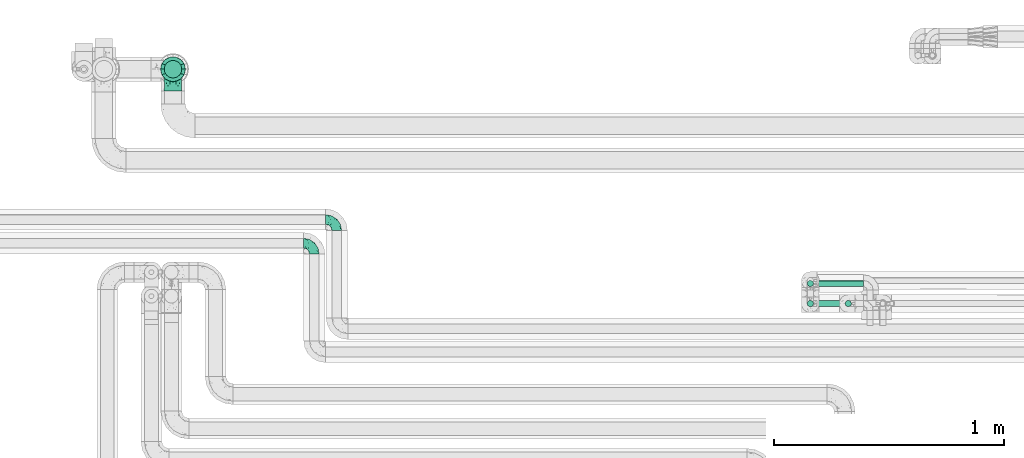
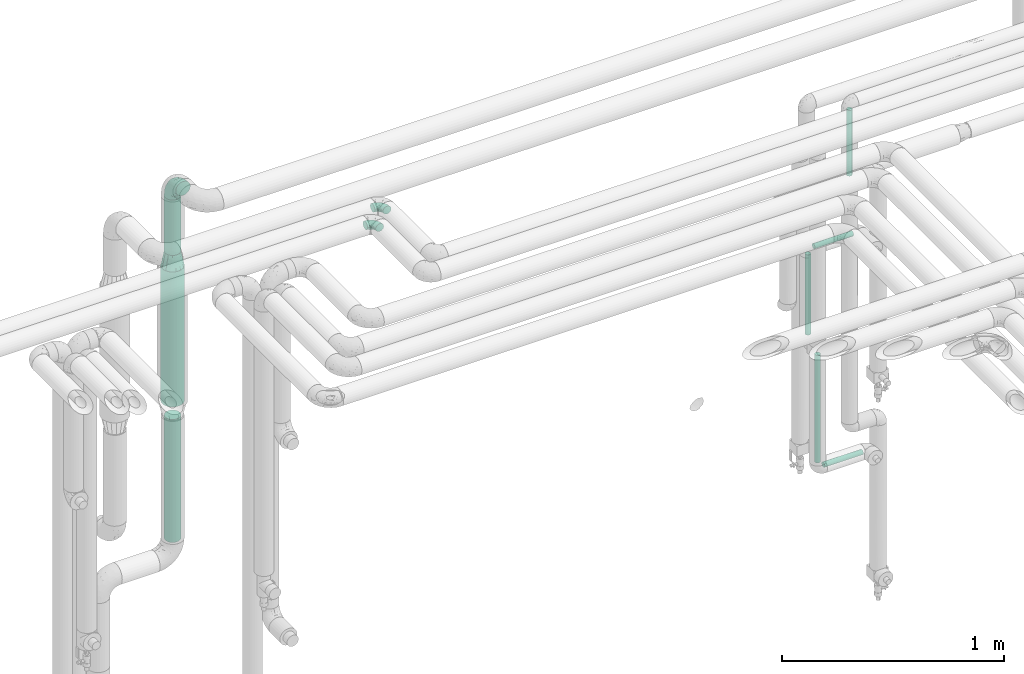
# One storey, part 643 of 824: 8 flow segments, 4 flow fittings.
"""IFC2X3 building model written with IfcOpenShell, lengths in millimetres."""

from ifc_helpers import new_model, entity, si_unit, converted_unit, derived_unit, direction, frame, origin, origin_2d_with_axis, place, context, subcontext, project, spatial, circle, extrude, faceted_brep, source, transform, mapped, material, type_object, type_shapes, element, save


model = new_model("IFC2X3")

# Units and contexts
model_context = context("Model", 3, precision=0.01, world=origin(), true_north=direction((6.12303176911189e-17, 1.0)))
body_context = subcontext(model_context, "Body", "Model", "MODEL_VIEW")
ifc_project = project(units=[si_unit("LENGTHUNIT", "METRE", prefix="MILLI"), si_unit("AREAUNIT", "SQUARE_METRE"), si_unit("VOLUMEUNIT", "CUBIC_METRE"), converted_unit("PLANEANGLEUNIT", "DEGREE", entity("IfcRatioMeasure", 0.0174532925199433), si_unit("PLANEANGLEUNIT", "RADIAN"), dimensions=[0, 0, 0, 0, 0, 0, 0]), si_unit("MASSUNIT", "GRAM", prefix="KILO"), derived_unit("MASSDENSITYUNIT", [(si_unit("MASSUNIT", "GRAM", prefix="KILO"), 1), (si_unit("LENGTHUNIT", "METRE"), -3)]), derived_unit("MOMENTOFINERTIAUNIT", [(si_unit("LENGTHUNIT", "METRE"), 4)]), si_unit("TIMEUNIT", "SECOND"), si_unit("FREQUENCYUNIT", "HERTZ"), si_unit("THERMODYNAMICTEMPERATUREUNIT", "DEGREE_CELSIUS"), derived_unit("THERMALTRANSMITTANCEUNIT", [(si_unit("MASSUNIT", "GRAM", prefix="KILO"), 1), (si_unit("THERMODYNAMICTEMPERATUREUNIT", "KELVIN"), -1), (si_unit("TIMEUNIT", "SECOND"), -3)]), derived_unit("VOLUMETRICFLOWRATEUNIT", [(si_unit("LENGTHUNIT", "METRE"), 3), (si_unit("TIMEUNIT", "SECOND"), -1)]), derived_unit("MASSFLOWRATEUNIT", [(si_unit("MASSUNIT", "GRAM", prefix="KILO"), 1), (si_unit("TIMEUNIT", "SECOND"), -1)]), derived_unit("ROTATIONALFREQUENCYUNIT", [(si_unit("TIMEUNIT", "SECOND"), -1)]), si_unit("ELECTRICCURRENTUNIT", "AMPERE"), si_unit("ELECTRICVOLTAGEUNIT", "VOLT"), si_unit("POWERUNIT", "WATT"), si_unit("FORCEUNIT", "NEWTON", prefix="KILO"), si_unit("ILLUMINANCEUNIT", "LUX"), si_unit("LUMINOUSFLUXUNIT", "LUMEN"), si_unit("LUMINOUSINTENSITYUNIT", "CANDELA"), derived_unit("USERDEFINED", [(si_unit("MASSUNIT", "GRAM", prefix="KILO"), -1), (si_unit("LENGTHUNIT", "METRE"), -2), (si_unit("TIMEUNIT", "SECOND"), 3), (si_unit("LUMINOUSFLUXUNIT", "LUMEN"), 1)]), derived_unit("LINEARVELOCITYUNIT", [(si_unit("LENGTHUNIT", "METRE"), 1), (si_unit("TIMEUNIT", "SECOND"), -1)]), si_unit("PRESSUREUNIT", "PASCAL"), derived_unit("USERDEFINED", [(si_unit("LENGTHUNIT", "METRE"), -2), (si_unit("MASSUNIT", "GRAM", prefix="KILO"), 1), (si_unit("TIMEUNIT", "SECOND"), -2)]), derived_unit("LINEARFORCEUNIT", [(si_unit("MASSUNIT", "GRAM", prefix="KILO"), 1), (si_unit("LENGTHUNIT", "METRE"), 1), (si_unit("TIMEUNIT", "SECOND"), -2), (si_unit("LENGTHUNIT", "METRE"), -1)]), derived_unit("PLANARFORCEUNIT", [(si_unit("MASSUNIT", "GRAM", prefix="KILO"), 1), (si_unit("LENGTHUNIT", "METRE"), 1), (si_unit("TIMEUNIT", "SECOND"), -2), (si_unit("LENGTHUNIT", "METRE"), -2)])], contexts=[model_context])

# Site, building, storey
site_placement = place(None, origin())
site = spatial("IfcSite", under=ifc_project, at=site_placement, CompositionType="ELEMENT")
building_placement = place(site_placement, origin())
building = spatial("IfcBuilding", under=site, at=building_placement, CompositionType="ELEMENT")
storey_placement = place(building_placement, frame((0.0, 0.0, 28200.0)))
storey = spatial("IfcBuildingStorey", under=building, at=storey_placement, CompositionType="ELEMENT", Elevation=28200.0)

# Flow segments
pipe_segment_type_1 = type_object("IfcPipeSegmentType", PredefinedType="NOTDEFINED")
flow_segment_1_placement = place(storey_placement, frame((31716.11, 19313.84, 2600.0)))
element("IfcFlowSegment", 1, at=flow_segment_1_placement, inside=storey, type_object=pipe_segment_type_1, context=body_context, shape_type="SweptSolid", body=[
    extrude(circle(Radius=38.0, at=origin_2d_with_axis()), frame((39.6, 39.6, 0.0)), (0.0, 0.0, 1.0), 305.000000000013),
])
flow_segment_2_placement = place(storey_placement, frame((31716.31, 19313.84, 1020.26)))
element("IfcFlowSegment", 2, at=flow_segment_2_placement, inside=storey, type_object=pipe_segment_type_1, context=body_context, shape_type="SweptSolid", body=[
    extrude(circle(Radius=38.0, at=origin_2d_with_axis()), frame((39.6, 39.6, 0.0), z_axis=(0.0, 0.0, 1.0), x_axis=(-1.0, 0.0, 0.0)), (0.0, 0.0, 1.0), 676.738359999959),
])
flow_segment_3_placement = place(storey_placement, frame((31700.11, 19297.84, 1777.0)))
element("IfcFlowSegment", 3, at=flow_segment_3_placement, inside=storey, type_object=pipe_segment_type_1, context=body_context, shape_type="SweptSolid", body=[
    extrude(circle(Radius=54.0, at=origin_2d_with_axis()), frame((55.6, 55.6, 0.0), z_axis=(0.0, 0.0, 1.0), x_axis=(-1.0, 0.0, 0.0)), (0.0, 0.0, 1.0), 743.000000000004),
])
pipe_segment_type_2 = type_object("IfcPipeSegmentType", PredefinedType="NOTDEFINED")
flow_segment_4_placement = place(storey_placement, frame((34510.39, 18319.92, 1089.1)))
element("IfcFlowSegment", 4, at=flow_segment_4_placement, inside=storey, type_object=pipe_segment_type_2, context=body_context, shape_type="SweptSolid", body=[
    extrude(circle(Radius=13.4, at=origin_2d_with_axis()), frame((15.0, 15.0, 0.0)), (0.0, 0.0, 1.0), 591.900000000008),
])
flow_segment_5_placement = place(storey_placement, frame((34554.49, 18319.92, 1045.0)))
element("IfcFlowSegment", 5, at=flow_segment_5_placement, inside=storey, type_object=pipe_segment_type_2, context=body_context, shape_type="SweptSolid", body=[
    extrude(circle(Radius=13.4, at=origin_2d_with_axis()), frame((0.0, 15.0, 15.0), z_axis=(1.0, 0.0, 0.0), x_axis=(0.0, -1.0, 0.0)), (0.0, 0.0, 1.0), 201.799999999997),
])
flow_segment_6_placement = place(storey_placement, frame((34554.49, 18406.91, 2195.0)))
element("IfcFlowSegment", 6, at=flow_segment_6_placement, inside=storey, type_object=pipe_segment_type_2, context=body_context, shape_type="SweptSolid", body=[
    extrude(circle(Radius=13.4, at=origin_2d_with_axis()), frame((0.0, 15.0, 15.0), z_axis=(1.0, 0.0, 0.0), x_axis=(0.0, 1.0, 0.0)), (0.0, 0.0, 1.0), 201.799999999997),
])
flow_segment_7_placement = place(storey_placement, frame((34510.39, 18406.91, 1739.1)))
element("IfcFlowSegment", 7, at=flow_segment_7_placement, inside=storey, type_object=pipe_segment_type_2, context=body_context, shape_type="SweptSolid", body=[
    extrude(circle(Radius=13.4, at=origin_2d_with_axis()), frame((15.0, 15.0, 0.0)), (0.0, 0.0, 1.0), 441.800000000021),
])
flow_segment_8_placement = place(storey_placement, frame((34675.43, 18319.92, 2609.0)))
element("IfcFlowSegment", 8, at=flow_segment_8_placement, inside=storey, type_object=pipe_segment_type_2, context=body_context, shape_type="SweptSolid", body=[
    extrude(circle(Radius=13.4, at=origin_2d_with_axis()), frame((15.0, 15.0, 0.0), z_axis=(0.0, 0.0, 1.0), x_axis=(-1.0, 0.0, 0.0)), (0.0, 0.0, 1.0), 362.066280646175),
])

# Flow fittings
ifc_material = material()
pipe_fitting_type_1 = type_object("IfcPipeFittingType", PredefinedType="NOTDEFINED", material=ifc_material)
shared_shape_1 = source(origin(), body_context, "Body", "Brep", [
    faceted_brep([(-48.0, 10.6, -18.36), (-48.0, 5.49, -20.48), (-48.0, 0.0, -21.2), (-48.0, -5.49, -20.48), (-48.0, -10.6, -18.36), (-48.0, -14.99, -14.99), (-48.0, -18.36, -10.6), (-48.0, -20.48, -5.49), (-48.0, -21.2, 0.0), (-48.0, -20.48, 5.49), (-48.0, -18.36, 10.6), (-48.0, -14.99, 14.99), (-48.0, -10.6, 18.36), (-48.0, -5.49, 20.48), (-48.0, 0.0, 21.2), (-48.0, 5.49, 20.48), (-48.0, 10.6, 18.36), (-48.0, 14.99, 14.99), (-48.0, 18.36, 10.6), (-48.0, 20.48, 5.49), (-48.0, 21.2, 0.0), (-48.0, 20.48, -5.49), (-48.0, 18.36, -10.6), (-48.0, 14.99, -14.99), (0.0, 48.0, -21.2), (-5.49, 48.0, -20.48), (-10.6, 48.0, -18.36), (-14.99, 48.0, -14.99), (-18.36, 48.0, -10.6), (-20.48, 48.0, -5.49), (-21.2, 48.0, 0.0), (-20.48, 48.0, 5.49), (-18.36, 48.0, 10.6), (-14.99, 48.0, 14.99), (-10.6, 48.0, 18.36), (-5.49, 48.0, 20.48), (0.0, 48.0, 21.2), (5.49, 48.0, 20.48), (10.6, 48.0, 18.36), (14.99, 48.0, 14.99), (18.36, 48.0, 10.6), (20.48, 48.0, 5.49), (21.2, 48.0, 0.0), (20.48, 48.0, -5.49), (18.36, 48.0, -10.6), (14.99, 48.0, -14.99), (10.6, 48.0, -18.36), (5.49, 48.0, -20.48), (-35.25, -16.22, 12.01), (-34.76, -18.57, 0.0), (-20.87, -12.37, 10.9), (-31.49, -11.78, 15.9), (-37.0, -2.58, 20.86), (-33.89, 3.62, 21.15), (-31.81, -18.14, 6.76), (-5.78, 5.78, 17.67), (-19.42, -4.1, 17.86), (-9.6, -3.39, 13.73), (-35.44, -7.73, 19.13), (11.78, 31.49, 15.9), (-5.93, -5.46, 6.95), (-18.45, -13.78, 5.46), (-10.29, -8.43, 0.0), (-24.6, 0.55, 20.62), (-37.28, 17.94, 13.81), (-33.38, 22.85, 9.59), (-41.46, 20.06, 8.75), (-29.51, 20.45, 15.16), (-15.04, 10.79, 21.13), (-7.08, 16.98, 20.93), (-8.39, 23.51, 21.15), (-40.86, 13.03, 17.26), (-8.05, 41.26, 19.83), (-3.21, 35.97, 21.14), (8.53, 19.66, 14.74), (4.1, 19.42, 17.86), (-37.72, 22.66, 4.78), (-37.07, 8.58, 19.98), (-13.0, 5.43, 19.97), (-3.78, 13.93, 19.7), (3.02, 8.69, 13.43), (-2.27, -0.05, 10.65), (6.22, 6.99, 7.09), (-22.25, 34.6, 9.45), (18.14, 31.81, 6.76), (16.22, 35.25, 12.01), (12.37, 20.87, 10.9), (7.73, 35.44, 19.13), (-21.52, -15.93, 0.0), (2.58, 37.0, 20.86), (18.57, 34.76, 0.0), (13.78, 18.45, 5.46), (15.93, 21.52, 0.0), (-20.03, -8.54, 14.9), (-28.6, 28.6, 5.16), (-24.79, 34.6, 0.0), (-34.6, 24.79, 0.0), (-22.81, 37.41, 4.68), (-23.36, 26.33, 14.79), (-13.68, 37.05, 17.49), (-17.72, 38.12, 13.73), (-26.25, 27.3, 11.24), (-9.71, 32.34, 20.14), (-17.26, 25.6, 18.71), (-26.33, 9.99, 20.77), (-24.06, 6.05, 21.2), (-25.02, 15.46, 19.56), (-24.3, 20.72, 17.57), (-31.95, 15.23, 17.8), (-13.53, 24.7, 20.21), (-17.6, 17.6, 20.6), (-0.55, 24.6, 20.62), (-11.41, -7.48, 10.43), (0.93, -0.93, 0.0), (8.43, 10.29, 0.0), (-11.41, -7.48, -10.43), (-20.1, -8.84, -14.66), (-9.6, -3.39, -13.73), (7.73, 35.44, -19.13), (4.1, 19.42, -17.86), (-0.55, 24.6, -20.62), (-38.12, 17.72, -13.73), (-37.05, 13.68, -17.49), (-32.34, 9.71, -20.14), (-41.26, 8.05, -19.83), (-37.41, 22.81, -4.68), (-23.51, 8.39, -21.15), (-35.97, 3.21, -21.14), (-28.6, 28.6, -5.16), (-31.81, -18.14, -6.76), (-18.45, -13.78, -5.46), (-25.6, 17.26, -18.71), (-19.42, -4.1, -17.86), (-17.94, 37.28, -13.81), (-22.85, 33.38, -9.59), (-20.06, 41.46, -8.75), (-31.49, -11.78, -15.9), (-35.25, -16.22, -12.01), (8.53, 19.66, -14.74), (11.78, 31.49, -15.9), (-9.99, 26.33, -20.77), (-6.05, 24.06, -21.2), (-10.79, 15.04, -21.13), (-37.0, -2.58, -20.86), (-16.98, 7.08, -20.93), (-5.43, 13.0, -19.97), (-13.93, 3.78, -19.7), (-20.87, -12.37, -10.9), (-26.33, 23.36, -14.79), (-22.66, 37.72, -4.78), (13.78, 18.45, -5.46), (18.14, 31.81, -6.76), (-15.46, 25.02, -19.56), (-20.72, 24.3, -17.57), (16.22, 35.25, -12.01), (-13.03, 40.86, -17.26), (-8.58, 37.07, -19.98), (2.58, 37.0, -20.86), (-3.62, 33.89, -21.15), (-34.6, 22.25, -9.45), (6.22, 6.99, -7.09), (-20.45, 29.51, -15.16), (-35.44, -7.73, -19.13), (12.37, 20.87, -10.9), (-27.3, 26.25, -11.24), (-15.23, 31.95, -17.8), (-24.7, 13.53, -20.21), (-24.6, 0.55, -20.62), (-5.78, 5.78, -17.67), (-17.6, 17.6, -20.6), (3.02, 8.69, -13.43), (-5.93, -5.46, -6.95), (-2.27, -0.05, -10.65)], [[[0, 1, 2, 3, 4, 5, 6, 7, 8, 9, 10, 11, 12, 13, 14, 15, 16, 17, 18, 19, 20, 21, 22, 23]], [[24, 25, 26, 27, 28, 29, 30, 31, 32, 33, 34, 35, 36, 37, 38, 39, 40, 41, 42, 43, 44, 45, 46, 47]], [[10, 48, 11]], [[9, 8, 49]], [[48, 50, 51]], [[14, 52, 53]], [[10, 54, 48]], [[9, 54, 10]], [[55, 56, 57]], [[51, 12, 11]], [[51, 58, 12]], [[59, 39, 38]], [[60, 61, 62]], [[58, 56, 63]], [[64, 65, 66]], [[67, 65, 64]], [[68, 69, 70]], [[16, 71, 17]], [[13, 52, 14]], [[35, 72, 73]], [[14, 53, 15]], [[17, 64, 18]], [[74, 59, 75]], [[20, 19, 76]], [[66, 19, 18]], [[77, 15, 53]], [[15, 77, 16]], [[69, 78, 79]], [[80, 81, 82]], [[32, 31, 83]], [[84, 85, 86]], [[59, 87, 75]], [[61, 54, 88]], [[36, 89, 37]], [[84, 41, 40]], [[36, 35, 73]], [[90, 41, 84]], [[40, 39, 85]], [[12, 58, 13]], [[85, 84, 40]], [[91, 84, 86]], [[84, 92, 90]], [[87, 38, 37]], [[93, 56, 51]], [[65, 94, 76]], [[94, 95, 96]], [[84, 91, 92]], [[95, 97, 30]], [[98, 99, 100]], [[76, 94, 96]], [[101, 98, 83]], [[100, 99, 33]], [[102, 70, 73]], [[103, 102, 99]], [[94, 97, 95]], [[72, 99, 102]], [[72, 35, 34]], [[34, 33, 99]], [[9, 49, 54]], [[87, 59, 38]], [[104, 105, 68]], [[106, 103, 107]], [[106, 77, 104]], [[71, 64, 17]], [[108, 107, 67]], [[33, 32, 100]], [[109, 103, 110]], [[102, 109, 70]], [[89, 73, 111]], [[50, 48, 54]], [[51, 11, 48]], [[56, 58, 51]], [[88, 54, 49]], [[52, 58, 63]], [[50, 112, 93]], [[56, 55, 78]], [[39, 59, 85]], [[86, 85, 59]], [[89, 87, 37]], [[42, 41, 90]], [[111, 79, 75]], [[111, 75, 87]], [[75, 55, 80]], [[104, 77, 53]], [[71, 77, 108]], [[32, 83, 100]], [[98, 100, 83]], [[99, 98, 103]], [[106, 107, 108]], [[68, 70, 110]], [[111, 73, 70]], [[68, 110, 104]], [[68, 63, 78]], [[57, 93, 112]], [[80, 55, 57]], [[61, 50, 54]], [[80, 82, 86]], [[81, 57, 112]], [[74, 86, 59]], [[60, 113, 82]], [[82, 114, 91]], [[101, 94, 65]], [[97, 94, 83]], [[73, 89, 36]], [[87, 89, 111]], [[58, 52, 13]], [[53, 52, 63]], [[104, 53, 105]], [[106, 104, 110]], [[20, 76, 96]], [[76, 19, 66]], [[103, 106, 110]], [[77, 106, 108]], [[103, 98, 107]], [[67, 107, 98]], [[67, 98, 101]], [[108, 67, 64]], [[53, 63, 105]], [[63, 68, 105]], [[83, 31, 97]], [[30, 97, 31]], [[62, 113, 60]], [[112, 61, 60]], [[61, 88, 62]], [[86, 82, 91]], [[56, 78, 63]], [[114, 82, 113]], [[114, 92, 91]], [[79, 78, 55]], [[75, 79, 55]], [[69, 79, 111]], [[70, 69, 111]], [[78, 69, 68]], [[77, 71, 16]], [[64, 71, 108]], [[64, 66, 18]], [[76, 66, 65]], [[99, 72, 34]], [[73, 72, 102]], [[94, 101, 83]], [[67, 101, 65]], [[75, 80, 74]], [[80, 86, 74]], [[70, 109, 110]], [[102, 103, 109]], [[50, 93, 51]], [[57, 56, 93]], [[61, 112, 50]], [[81, 112, 60]], [[82, 81, 60]], [[80, 57, 81]], [[115, 116, 117]], [[118, 119, 120]], [[121, 122, 23]], [[123, 124, 122]], [[96, 125, 20]], [[123, 126, 127]], [[128, 96, 95]], [[129, 130, 88]], [[123, 122, 131]], [[116, 132, 117]], [[133, 134, 135]], [[0, 124, 1]], [[5, 136, 137]], [[138, 119, 139]], [[129, 88, 49]], [[140, 141, 142]], [[6, 5, 137]], [[46, 118, 47]], [[143, 3, 2]], [[144, 145, 146]], [[6, 129, 7]], [[129, 137, 147]], [[127, 2, 1]], [[148, 122, 121]], [[128, 125, 96]], [[134, 128, 149]], [[95, 149, 128]], [[150, 151, 92]], [[30, 29, 149]], [[152, 131, 153]], [[27, 133, 28]], [[154, 45, 44]], [[136, 5, 4]], [[27, 26, 155]], [[156, 26, 25]], [[24, 157, 158]], [[24, 47, 157]], [[22, 21, 159]], [[160, 150, 114]], [[134, 133, 161]], [[142, 144, 126]], [[46, 139, 118]], [[162, 136, 4]], [[156, 25, 158]], [[1, 124, 127]], [[115, 147, 116]], [[45, 154, 139]], [[139, 46, 45]], [[154, 163, 139]], [[162, 4, 3]], [[42, 90, 43]], [[130, 129, 147]], [[49, 7, 129]], [[43, 151, 44]], [[0, 23, 122]], [[24, 158, 25]], [[136, 162, 132]], [[135, 29, 28]], [[43, 90, 151]], [[164, 148, 159]], [[152, 156, 140]], [[155, 133, 27]], [[165, 153, 161]], [[23, 22, 121]], [[123, 131, 166]], [[123, 166, 126]], [[143, 127, 167]], [[147, 137, 136]], [[8, 7, 49]], [[129, 6, 137]], [[143, 162, 3]], [[167, 146, 132]], [[167, 132, 162]], [[132, 168, 117]], [[44, 151, 154]], [[92, 151, 90]], [[163, 154, 151]], [[119, 118, 139]], [[157, 118, 120]], [[138, 139, 163]], [[119, 168, 145]], [[140, 156, 158]], [[155, 156, 165]], [[22, 159, 121]], [[148, 121, 159]], [[122, 148, 131]], [[152, 153, 165]], [[142, 126, 169]], [[167, 127, 126]], [[142, 169, 140]], [[142, 120, 145]], [[168, 170, 117]], [[160, 171, 172]], [[115, 172, 171]], [[171, 62, 130]], [[119, 170, 168]], [[170, 163, 160]], [[150, 163, 151]], [[113, 171, 160]], [[164, 128, 134]], [[125, 128, 159]], [[127, 143, 2]], [[162, 143, 167]], [[118, 157, 47]], [[158, 157, 120]], [[140, 158, 141]], [[152, 140, 169]], [[30, 149, 95]], [[149, 29, 135]], [[131, 152, 169]], [[156, 152, 165]], [[131, 148, 153]], [[161, 153, 148]], [[161, 148, 164]], [[165, 161, 133]], [[158, 120, 141]], [[120, 142, 141]], [[159, 21, 125]], [[20, 125, 21]], [[115, 130, 147]], [[114, 113, 160]], [[62, 171, 113]], [[62, 88, 130]], [[160, 163, 150]], [[150, 92, 114]], [[119, 145, 120]], [[146, 145, 168]], [[132, 146, 168]], [[144, 146, 167]], [[126, 144, 167]], [[145, 144, 142]], [[156, 155, 26]], [[133, 155, 165]], [[133, 135, 28]], [[149, 135, 134]], [[122, 124, 0]], [[127, 124, 123]], [[128, 164, 159]], [[161, 164, 134]], [[163, 170, 138]], [[170, 119, 138]], [[131, 169, 166]], [[126, 166, 169]], [[147, 136, 116]], [[132, 116, 136]], [[172, 115, 117]], [[130, 115, 171]], [[117, 170, 172]], [[160, 172, 170]]]),
])
type_shapes(pipe_fitting_type_1, [shared_shape_1])
for number, where, z_axis, x_axis in (
    (9, (32370.03, 18597.5, 2999.5), (0.0, 0.0, 1.0), (0.0, 1.0, 0.0)),
    (10, (32467.53, 18700.0, 2999.91), (0.0, 0.0, 1.0), (0.0, 1.0, 0.0)),
):
    element("IfcFlowFitting", number, at=place(storey_placement, frame(where, z_axis=z_axis, x_axis=x_axis)), inside=storey, type_object=pipe_fitting_type_1, material=ifc_material, context=body_context, shape_type="MappedRepresentation", body=[
        mapped(shared_shape_1, transform((0.0, 0.0, 0.0), scale=1.0)),
    ])
pipe_fitting_type_2 = type_object("IfcPipeFittingType", PredefinedType="NOTDEFINED", material=ifc_material)
shared_shape_2 = source(origin(), body_context, "Body", "Brep", [
    faceted_brep([(-95.0, 19.02, -32.95), (-95.0, 9.85, -36.75), (-95.0, 0.0, -38.05), (-95.0, -9.85, -36.75), (-95.0, -19.03, -32.95), (-95.0, -26.91, -26.91), (-95.0, -32.95, -19.03), (-95.0, -36.75, -9.85), (-95.0, -38.05, 0.0), (-95.0, -36.75, 9.85), (-95.0, -32.95, 19.02), (-95.0, -26.91, 26.91), (-95.0, -19.03, 32.95), (-95.0, -9.85, 36.75), (-95.0, 0.0, 38.05), (-95.0, 9.85, 36.75), (-95.0, 19.02, 32.95), (-95.0, 26.91, 26.91), (-95.0, 32.95, 19.02), (-95.0, 36.75, 9.85), (-95.0, 38.05, 0.0), (-95.0, 36.75, -9.85), (-95.0, 32.95, -19.03), (-95.0, 26.91, -26.91), (0.0, 95.0, -38.05), (-9.85, 95.0, -36.75), (-19.02, 95.0, -32.95), (-26.91, 95.0, -26.91), (-32.95, 95.0, -19.03), (-36.75, 95.0, -9.85), (-38.05, 95.0, 0.0), (-36.75, 95.0, 9.85), (-32.95, 95.0, 19.02), (-26.91, 95.0, 26.91), (-19.02, 95.0, 32.95), (-9.85, 95.0, 36.75), (0.0, 95.0, 38.05), (9.85, 95.0, 36.75), (19.03, 95.0, 32.95), (26.91, 95.0, 26.91), (32.95, 95.0, 19.02), (36.75, 95.0, 9.85), (38.05, 95.0, 0.0), (36.75, 95.0, -9.85), (32.95, 95.0, -19.03), (26.91, 95.0, -26.91), (19.03, 95.0, -32.95), (9.85, 95.0, -36.75), (-7.99, -4.96, 6.3), (-0.92, 0.92, 0.0), (4.62, 8.1, 8.01), (-76.19, -35.57, 0.0), (-64.32, -32.32, 12.43), (20.51, 62.45, 28.68), (-60.56, -33.52, 0.0), (-70.4, -13.47, 34.42), (-39.61, -5.88, 32.32), (-49.6, 2.07, 37.1), (-70.34, -28.81, 21.71), (14.64, 40.81, 26.5), (5.88, 39.61, 32.32), (3.59, 20.77, 25.31), (-40.45, 68.06, 16.75), (-62.45, -20.51, 28.68), (-44.52, -26.87, 0.0), (-28.47, -20.22, 0.0), (-26.43, -17.83, 8.75), (-76.1, 39.63, 10.76), (-72.74, 37.58, 18.19), (-60.35, 46.18, 14.61), (-13.4, 13.4, 32.12), (-20.77, -3.59, 25.31), (-14.66, 81.47, 35.56), (-6.22, 71.26, 37.92), (-57.5, 42.48, 22.79), (-15.0, 34.74, 37.7), (-27.1, 12.08, 36.05), (-9.2, 28.81, 35.63), (-79.98, 23.7, 30.95), (-73.68, -4.3, 37.48), (-30.74, 21.67, 37.97), (-62.36, 47.59, 6.79), (-72.71, 32.83, 24.69), (-67.42, 7.02, 37.95), (-32.13, 75.27, 24.51), (-43.46, 51.47, 26.26), (-24.98, 73.15, 31.29), (20.59, 41.28, 19.85), (7.79, 16.09, 15.86), (-73.21, 42.39, 0.0), (-54.73, 54.73, 0.0), (-73.44, 15.79, 35.79), (-5.94, 4.32, 20.43), (28.81, 70.34, 21.71), (32.32, 64.32, 12.43), (-53.59, 26.2, 35.09), (-52.02, 19.31, 37.21), (21.38, 33.53, 10.34), (26.87, 44.52, 0.0), (-48.28, 12.14, 38.05), (4.3, 73.68, 37.48), (-44.08, -25.52, 12.79), (-41.28, -20.59, 19.85), (35.57, 76.19, 0.0), (-47.26, 54.3, 20.18), (-47.4, 61.99, 8.58), (-42.39, 73.21, 0.0), (-39.67, 78.86, 7.21), (-45.69, 36.84, 33.11), (-32.83, 50.13, 33.35), (13.47, 70.4, 34.42), (-18.25, 63.73, 36.07), (-40.63, -13.75, 27.22), (-16.63, 46.37, 37.95), (-53.47, 38.79, 28.59), (-26.07, 48.54, 36.15), (-34.51, 34.51, 36.86), (-2.07, 49.6, 37.1), (-22.79, -10.49, 19.23), (-61.73, 28.67, 31.87), (9.65, 14.7, 0.0), (20.22, 28.47, 0.0), (33.52, 60.56, 0.0), (-11.42, -5.44, 13.25), (-14.7, -9.65, 0.0), (-81.47, 14.66, -35.56), (-62.45, -20.51, -28.68), (-71.26, 6.22, -37.92), (-75.27, 32.13, -24.51), (-73.15, 24.98, -31.29), (13.47, 70.4, -34.42), (5.88, 39.61, -32.32), (-2.07, 49.6, -37.1), (-78.86, 39.67, -7.21), (-70.4, -13.47, -34.42), (-39.61, -5.88, -32.32), (-61.99, 47.4, -8.58), (32.32, 64.32, -12.43), (28.81, 70.34, -21.71), (-63.73, 18.25, -36.07), (-50.13, 32.83, -33.35), (4.3, 73.68, -37.48), (-7.02, 67.42, -37.95), (-39.63, 76.1, -10.76), (-46.18, 60.35, -14.61), (-47.59, 62.36, -6.79), (-64.32, -32.32, -12.43), (-26.2, 53.59, -35.09), (-15.79, 73.44, -35.79), (-19.31, 52.02, -37.21), (-37.58, 72.74, -18.19), (-70.34, -28.81, -21.71), (-42.48, 57.5, -22.79), (-38.79, 53.47, -28.59), (-51.47, 43.46, -26.26), (-32.83, 72.71, -24.69), (-46.37, 16.63, -37.95), (-73.68, -4.3, -37.48), (-41.28, -20.59, -19.85), (-44.08, -25.52, -12.79), (13.75, 40.63, -27.22), (20.51, 62.45, -28.68), (-68.06, 40.45, -16.75), (-54.3, 47.26, -20.18), (-12.14, 48.28, -38.05), (-21.67, 30.74, -37.97), (-36.84, 45.69, -33.11), (-11.42, -5.44, -13.25), (7.79, 16.09, -15.86), (4.62, 8.1, -8.01), (-23.7, 79.98, -30.95), (-26.43, -17.83, -8.75), (-7.99, -4.96, -6.3), (-40.81, -14.64, -26.5), (-20.77, -3.59, -25.31), (-34.74, 15.0, -37.7), (-12.08, 27.1, -36.05), (-28.81, 9.2, -35.63), (-22.79, -10.49, -19.23), (21.38, 33.53, -10.34), (20.59, 41.28, -19.85), (-48.54, 26.07, -36.15), (-49.6, 2.07, -37.1), (-13.4, 13.4, -32.12), (3.59, 20.77, -25.31), (-28.67, 61.73, -31.87), (-34.51, 34.51, -36.86), (-5.94, 4.32, -20.43)], [[[0, 1, 2, 3, 4, 5, 6, 7, 8, 9, 10, 11, 12, 13, 14, 15, 16, 17, 18, 19, 20, 21, 22, 23]], [[24, 25, 26, 27, 28, 29, 30, 31, 32, 33, 34, 35, 36, 37, 38, 39, 40, 41, 42, 43, 44, 45, 46, 47]], [[48, 49, 50]], [[51, 52, 9]], [[53, 39, 38]], [[9, 52, 10]], [[54, 52, 51]], [[55, 56, 57]], [[11, 10, 58]], [[59, 60, 61]], [[32, 31, 62]], [[63, 12, 11]], [[63, 55, 12]], [[64, 65, 66]], [[67, 68, 69]], [[70, 56, 71]], [[35, 72, 73]], [[69, 68, 74]], [[75, 76, 77]], [[16, 78, 17]], [[13, 79, 14]], [[76, 75, 80]], [[67, 69, 81]], [[18, 17, 82]], [[14, 79, 83]], [[20, 19, 67]], [[84, 85, 86]], [[87, 61, 88]], [[89, 81, 90]], [[18, 82, 68]], [[15, 91, 16]], [[14, 83, 15]], [[71, 92, 61]], [[17, 78, 82]], [[93, 87, 94]], [[95, 91, 96]], [[97, 98, 94]], [[86, 72, 34]], [[96, 99, 80]], [[37, 36, 100]], [[40, 39, 93]], [[40, 94, 41]], [[64, 66, 101]], [[93, 94, 40]], [[58, 102, 63]], [[94, 103, 41]], [[94, 87, 97]], [[104, 69, 74]], [[34, 33, 86]], [[105, 69, 104]], [[52, 58, 10]], [[106, 107, 30]], [[108, 109, 85]], [[105, 106, 90]], [[53, 110, 60]], [[86, 111, 72]], [[86, 109, 111]], [[33, 84, 86]], [[12, 55, 13]], [[112, 56, 63]], [[110, 38, 37]], [[34, 72, 35]], [[36, 35, 73]], [[111, 113, 73]], [[105, 107, 106]], [[110, 53, 38]], [[74, 114, 85]], [[91, 15, 83]], [[105, 90, 81]], [[107, 62, 31]], [[33, 32, 84]], [[115, 109, 116]], [[111, 115, 113]], [[100, 73, 117]], [[56, 55, 63]], [[79, 55, 57]], [[102, 118, 112]], [[56, 70, 76]], [[100, 110, 37]], [[117, 77, 60]], [[117, 60, 110]], [[60, 70, 61]], [[58, 52, 101]], [[63, 11, 58]], [[39, 53, 93]], [[87, 93, 53]], [[96, 91, 83]], [[78, 91, 119]], [[32, 62, 84]], [[84, 62, 104]], [[86, 85, 109]], [[85, 114, 108]], [[80, 113, 116]], [[117, 73, 113]], [[80, 116, 96]], [[80, 57, 76]], [[71, 112, 118]], [[61, 87, 59]], [[62, 107, 105]], [[97, 120, 121]], [[70, 71, 61]], [[71, 118, 92]], [[73, 100, 36]], [[110, 100, 117]], [[55, 79, 13]], [[83, 79, 57]], [[96, 83, 99]], [[116, 108, 95]], [[50, 97, 88]], [[97, 87, 88]], [[50, 49, 120]], [[122, 94, 98]], [[89, 20, 67]], [[105, 81, 69]], [[89, 67, 81]], [[68, 19, 18]], [[68, 67, 19]], [[74, 68, 82]], [[114, 82, 119]], [[74, 85, 104]], [[82, 114, 74]], [[114, 119, 108]], [[95, 108, 119]], [[116, 109, 108]], [[123, 48, 50]], [[97, 50, 120]], [[123, 50, 88]], [[91, 95, 119]], [[116, 95, 96]], [[84, 104, 85]], [[104, 62, 105]], [[83, 57, 99]], [[57, 80, 99]], [[66, 48, 123]], [[66, 124, 48]], [[118, 66, 123]], [[124, 66, 65]], [[66, 118, 101]], [[54, 64, 52]], [[124, 49, 48]], [[30, 107, 31]], [[91, 78, 16]], [[82, 78, 119]], [[56, 76, 57]], [[77, 76, 70]], [[60, 77, 70]], [[77, 117, 75]], [[117, 113, 75]], [[113, 80, 75]], [[9, 8, 51]], [[103, 94, 122]], [[103, 42, 41]], [[73, 72, 111]], [[113, 115, 116]], [[111, 109, 115]], [[102, 112, 63]], [[71, 56, 112]], [[118, 102, 101]], [[92, 123, 88]], [[123, 92, 118]], [[61, 92, 88]], [[87, 53, 59]], [[60, 59, 53]], [[97, 121, 98]], [[58, 101, 102]], [[64, 101, 52]], [[125, 1, 0]], [[126, 5, 4]], [[2, 1, 127]], [[1, 125, 127]], [[128, 129, 23]], [[130, 131, 132]], [[89, 133, 20]], [[126, 134, 135]], [[136, 89, 90]], [[137, 138, 44]], [[139, 129, 140]], [[24, 141, 142]], [[143, 144, 145]], [[125, 129, 139]], [[6, 146, 7]], [[147, 148, 149]], [[146, 51, 7]], [[143, 150, 144]], [[146, 6, 151]], [[152, 153, 154]], [[126, 4, 134]], [[0, 23, 129]], [[28, 155, 150]], [[43, 42, 103]], [[54, 146, 64]], [[139, 156, 127]], [[157, 3, 2]], [[151, 158, 159]], [[160, 131, 161]], [[22, 21, 162]], [[136, 144, 163]], [[149, 164, 165]], [[24, 142, 25]], [[166, 140, 154]], [[154, 129, 128]], [[143, 30, 29]], [[167, 168, 169]], [[155, 28, 27]], [[26, 170, 27]], [[171, 167, 172]], [[26, 25, 148]], [[27, 170, 155]], [[173, 135, 174]], [[144, 150, 152]], [[175, 176, 177]], [[24, 47, 141]], [[45, 161, 46]], [[148, 25, 142]], [[176, 175, 165]], [[64, 159, 171]], [[138, 45, 44]], [[130, 46, 161]], [[137, 44, 43]], [[178, 159, 158]], [[137, 103, 122]], [[163, 144, 152]], [[136, 133, 89]], [[103, 137, 43]], [[6, 5, 151]], [[178, 158, 173]], [[134, 4, 3]], [[178, 173, 174]], [[137, 98, 179]], [[145, 90, 106]], [[138, 180, 161]], [[46, 130, 47]], [[136, 90, 145]], [[133, 162, 21]], [[23, 22, 128]], [[139, 140, 181]], [[139, 181, 156]], [[157, 127, 182]], [[157, 134, 3]], [[182, 177, 135]], [[182, 135, 134]], [[135, 183, 174]], [[131, 130, 161]], [[141, 130, 132]], [[160, 180, 184]], [[131, 183, 176]], [[5, 126, 151]], [[158, 151, 126]], [[180, 138, 137]], [[161, 45, 138]], [[149, 148, 142]], [[170, 148, 185]], [[22, 162, 128]], [[128, 162, 163]], [[129, 154, 140]], [[154, 153, 166]], [[165, 156, 186]], [[182, 127, 156]], [[165, 186, 149]], [[165, 132, 176]], [[131, 184, 183]], [[187, 167, 178]], [[184, 168, 187]], [[167, 169, 172]], [[184, 180, 168]], [[174, 183, 184]], [[127, 157, 2]], [[134, 157, 182]], [[130, 141, 47]], [[142, 141, 132]], [[149, 142, 164]], [[186, 166, 147]], [[180, 179, 168]], [[169, 179, 120]], [[137, 179, 180]], [[179, 121, 120]], [[106, 30, 143]], [[136, 145, 144]], [[106, 143, 145]], [[150, 29, 28]], [[150, 143, 29]], [[152, 150, 155]], [[153, 155, 185]], [[152, 154, 163]], [[155, 153, 152]], [[153, 185, 166]], [[147, 166, 185]], [[186, 140, 166]], [[169, 120, 49]], [[169, 49, 172]], [[179, 169, 168]], [[148, 147, 185]], [[186, 147, 149]], [[128, 163, 154]], [[163, 162, 136]], [[142, 132, 164]], [[132, 165, 164]], [[171, 124, 65]], [[124, 171, 172]], [[64, 146, 159]], [[171, 159, 178]], [[171, 65, 64]], [[172, 49, 124]], [[162, 133, 136]], [[20, 133, 21]], [[148, 170, 26]], [[155, 170, 185]], [[131, 176, 132]], [[177, 176, 183]], [[135, 177, 183]], [[177, 182, 175]], [[182, 156, 175]], [[156, 165, 175]], [[51, 146, 54]], [[51, 8, 7]], [[129, 125, 0]], [[127, 125, 139]], [[140, 186, 181]], [[156, 181, 186]], [[158, 126, 173]], [[135, 173, 126]], [[187, 178, 174]], [[171, 178, 167]], [[184, 187, 174]], [[167, 187, 168]], [[180, 160, 161]], [[184, 131, 160]], [[98, 137, 122]], [[98, 121, 179]], [[151, 159, 146]]]),
])
type_shapes(pipe_fitting_type_2, [shared_shape_2])
flow_fitting_1_placement = place(storey_placement, frame((31755.7, 19353.43, 3000.0), z_axis=(-1.0, 0.0, 0.0), x_axis=(0.0, 1.0, 0.0)))
element("IfcFlowFitting", 11, at=flow_fitting_1_placement, inside=storey, type_object=pipe_fitting_type_2, material=ifc_material, context=body_context, shape_type="MappedRepresentation", body=[
    mapped(shared_shape_2, transform((0.0, 0.0, 0.0), scale=1.0)),
])
pipe_fitting_type_3 = type_object("IfcPipeFittingType", PredefinedType="NOTDEFINED", material=ifc_material)
shared_shape_3 = source(origin(), body_context, "Body", "Brep", [
    faceted_brep([(80.0, -19.0, 32.91), (80.0, -25.95, 25.95), (80.0, -32.91, 19.0), (80.0, -35.45, 9.5), (80.0, -38.0, 0.0), (80.0, -35.45, -9.5), (80.0, -32.91, -19.0), (80.0, -25.95, -25.95), (80.0, -19.0, -32.91), (80.0, -9.5, -35.45), (80.0, 0.0, -38.0), (80.0, 9.5, -35.45), (80.0, 19.0, -32.91), (80.0, 25.95, -25.95), (80.0, 32.91, -19.0), (80.0, 35.45, -9.5), (80.0, 38.0, 0.0), (80.0, 35.45, 9.5), (80.0, 32.91, 19.0), (80.0, 25.95, 25.95), (80.0, 19.0, 32.91), (80.0, 9.5, 35.45), (80.0, 0.0, 38.0), (80.0, -9.5, 35.45), (0.0, 22.84, 47.43), (0.0, 33.67, 42.22), (0.0, 41.16, 32.82), (0.0, 48.65, 23.43), (0.0, 51.33, 11.71), (0.0, 54.0, 0.0), (0.0, 51.33, -11.71), (0.0, 48.65, -23.43), (0.0, 41.16, -32.82), (0.0, 33.67, -42.22), (0.0, 22.84, -47.43), (0.0, 12.02, -52.65), (0.0, 0.0, -52.65), (0.0, -12.02, -52.65), (0.0, -22.84, -47.43), (0.0, -33.67, -42.22), (0.0, -41.16, -32.82), (0.0, -48.65, -23.43), (0.0, -51.33, -11.71), (0.0, -54.0, 0.0), (0.0, -51.33, 11.71), (0.0, -48.65, 23.43), (0.0, -41.16, 32.82), (0.0, -33.67, 42.22), (0.0, -22.84, 47.43), (0.0, -12.02, 52.65), (0.0, 0.0, 52.65), (0.0, 12.02, 52.65)], [[[0, 1, 2, 3, 4, 5, 6, 7, 8, 9, 10, 11, 12, 13, 14, 15, 16, 17, 18, 19, 20, 21, 22, 23]], [[24, 25, 26, 27, 28, 29, 30, 31, 32, 33, 34, 35, 36, 37, 38, 39, 40, 41, 42, 43, 44, 45, 46, 47, 48, 49, 50, 51]], [[15, 31, 30]], [[42, 4, 43]], [[32, 31, 14]], [[14, 31, 15]], [[34, 11, 35]], [[4, 42, 5]], [[13, 12, 33]], [[10, 37, 36, 35]], [[8, 39, 38]], [[39, 8, 7]], [[38, 9, 8]], [[34, 33, 12]], [[11, 10, 35]], [[40, 6, 41]], [[13, 33, 32]], [[16, 15, 30]], [[38, 37, 9]], [[16, 30, 29]], [[41, 6, 5]], [[6, 40, 7]], [[14, 13, 32]], [[11, 34, 12]], [[37, 10, 9]], [[40, 39, 7]], [[42, 41, 5]], [[3, 45, 44]], [[28, 16, 29]], [[46, 45, 2]], [[2, 45, 3]], [[48, 23, 49]], [[16, 28, 17]], [[1, 0, 47]], [[22, 51, 50, 49]], [[20, 25, 24]], [[25, 20, 19]], [[24, 21, 20]], [[48, 47, 0]], [[23, 22, 49]], [[26, 18, 27]], [[1, 47, 46]], [[4, 3, 44]], [[24, 51, 21]], [[4, 44, 43]], [[27, 18, 17]], [[18, 26, 19]], [[2, 1, 46]], [[23, 48, 0]], [[51, 22, 21]], [[26, 25, 19]], [[28, 27, 17]]]),
])
type_shapes(pipe_fitting_type_3, [shared_shape_3])
flow_fitting_2_placement = place(storey_placement, frame((31755.7, 19353.43, 2520.0), z_axis=(0.0, 1.0, 0.0), x_axis=(0.0, 0.0, 1.0)))
element("IfcFlowFitting", 12, at=flow_fitting_2_placement, inside=storey, type_object=pipe_fitting_type_3, material=ifc_material, context=body_context, shape_type="MappedRepresentation", body=[
    mapped(shared_shape_3, transform((0.0, 0.0, 0.0), scale=1.0)),
])

save(model, "model.ifc")
